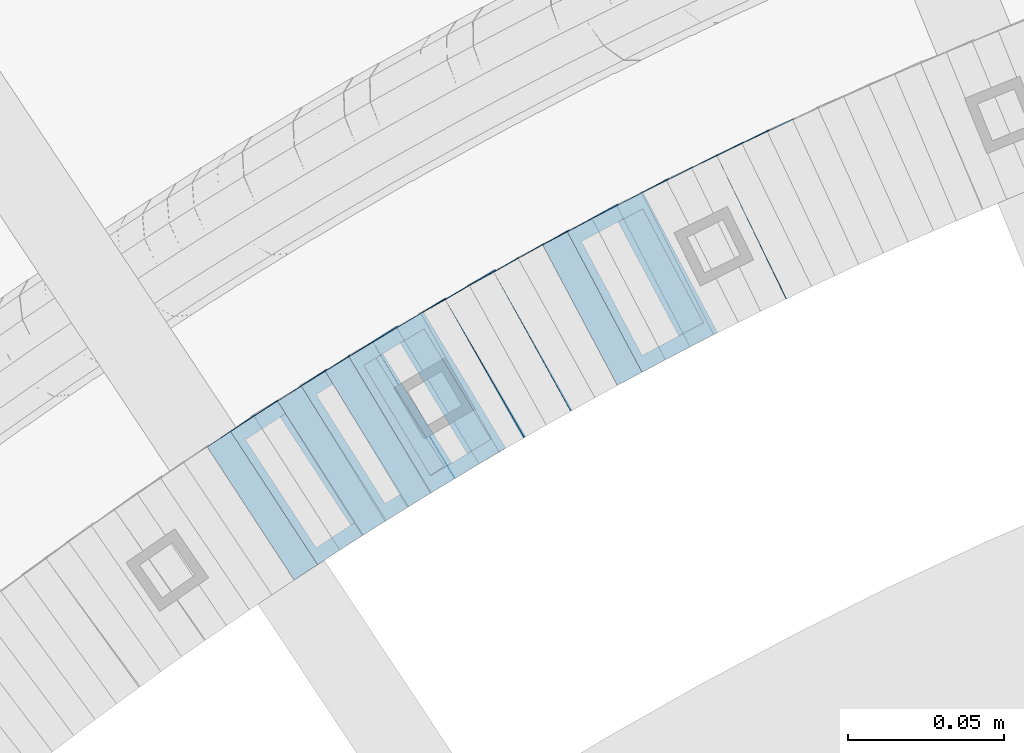
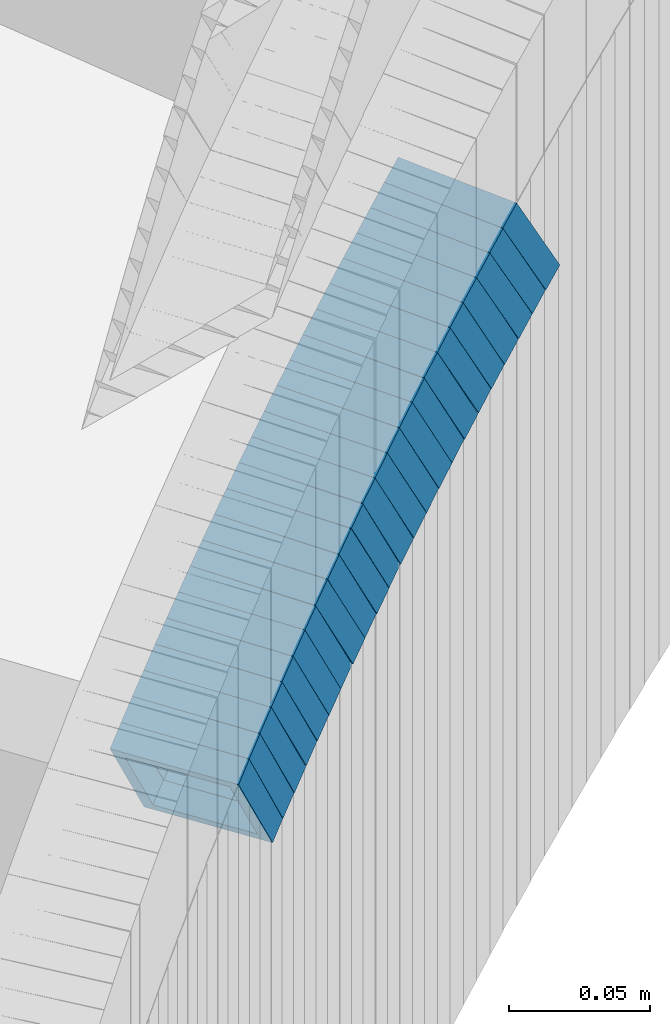
# One storey, part 748 of 975: 23 members.
"""IFC2X3 building model written with IfcOpenShell, lengths in millimetres."""

from ifc_helpers import new_model, si_unit, frame, origin_with_axes, place, context, subcontext, project, spatial, faceted_brep, material, type_object, element, save


model = new_model("IFC2X3")

# Units and contexts
model_context = context("Model", 3, precision=1e-05, world=origin_with_axes())
body_context = subcontext(model_context, "Body", "Model", "MODEL_VIEW")
ifc_project = project(units=[si_unit("LENGTHUNIT", "METRE", prefix="MILLI"), si_unit("AREAUNIT", "SQUARE_METRE"), si_unit("VOLUMEUNIT", "CUBIC_METRE"), si_unit("MASSUNIT", "GRAM", prefix="KILO"), si_unit("TIMEUNIT", "SECOND"), si_unit("PLANEANGLEUNIT", "RADIAN"), si_unit("SOLIDANGLEUNIT", "STERADIAN"), si_unit("THERMODYNAMICTEMPERATUREUNIT", "DEGREE_CELSIUS"), si_unit("LUMINOUSINTENSITYUNIT", "LUMEN")], contexts=[model_context])

# Site, building, storey
site_placement = place(None, origin_with_axes())
site = spatial("IfcSite", under=ifc_project, at=site_placement, CompositionType="ELEMENT")
building_placement = place(site_placement, origin_with_axes())
building = spatial("IfcBuilding", under=site, at=building_placement, Name="Undefined", CompositionType="ELEMENT")
storey_placement = place(building_placement, origin_with_axes())
storey = spatial("IfcBuildingStorey", under=building, at=storey_placement, Name="Undefined", CompositionType="ELEMENT", Elevation=0.0)

# Members
ifc_material = material()
member_type = type_object("IfcMemberType", Name="HSS2X2X.188_TUBES", PredefinedType="NOTDEFINED")
member_1_placement = place(storey_placement, frame((34127.8194134494, 4662.12892975427, 626.710672196454), z_axis=(-0.438202246944682, 0.898876404614467, -1.0214671419817e-10), x_axis=(0.756943389157108, 0.369009902076498, 0.539322165111767)))
element("IfcMember", 1, at=member_1_placement, inside=storey, type_object=member_type, material=ifc_material, Name="WALL", ObjectType="HSS2X2X.188_TUBES", context=body_context, shape_type="Brep", body=[
    faceted_brep([(0.0, 20.6374999999753, -20.6375000000298), (0.0, -20.6375000000153, -20.6375000000153), (10.5744976239494, -20.6375000000207, -20.6375000000335), (10.5744976239657, 20.6375000000098, -20.637500000008), (0.0, -20.6374999999825, 20.6375000000335), (10.5744976239639, -20.6375000000244, 20.6374999999753), (0.0, 20.6375000000116, 20.6375000000189), (10.5744976239803, 20.6374999999989, 20.6374999999935), (0.0, 25.3999999999724, -25.4000000000342), (0.0, 25.400000000016, 25.4000000000196), (10.5744976239857, 25.4000000000051, 25.4000000000015), (10.5744976239675, 25.4000000000124, -25.4000000000051), (0.0, -25.399999999976, 25.4000000000378), (10.5744976239639, -25.4000000000287, 25.3999999999724), (0.0, -25.400000000016, -25.4000000000196), (10.5744976239494, -25.4000000000215, -25.4000000000378)], [[[0, 1, 2, 3]], [[1, 4, 5, 2]], [[4, 6, 7, 5]], [[6, 0, 3, 7]], [[8, 9, 10, 11]], [[9, 12, 13, 10]], [[12, 14, 15, 13]], [[14, 8, 11, 15]], [[13, 15, 11, 10], [5, 7, 3, 2]], [[14, 12, 9, 8], [6, 4, 1, 0]]]),
])
member_2_placement = place(storey_placement, frame((34120.0954326913, 4658.41942418444, 620.988545204124), z_axis=(-0.447213595461908, 0.894427191018941, 1.31206434161868e-10), x_axis=(0.750454514252586, 0.375227257126378, 0.544079523183265)))
element("IfcMember", 2, at=member_2_placement, inside=storey, type_object=member_type, material=ifc_material, Name="WALL", ObjectType="HSS2X2X.188_TUBES", context=body_context, shape_type="Brep", body=[
    faceted_brep([(0.0, 20.6374999999753, -20.6375000000298), (0.0, -20.6375000000153, -20.6375000000153), (10.6625512894789, -20.6374999999625, -20.6374999999389), (10.6625512893879, 20.6374999999789, -20.6375000000371), (0.0, -20.6374999999825, 20.6375000000335), (10.6625512894352, -20.6374999999989, 20.6375000000153), (0.0, 20.6375000000116, 20.6375000000189), (10.6625512893443, 20.6374999999443, 20.6374999999134), (0.0, 25.3999999999724, -25.4000000000342), (0.0, 25.400000000016, 25.4000000000196), (10.6625512893297, 25.3999999999342, 25.3999999998996), (10.6625512893916, 25.399999999976, -25.4000000000415), (0.0, -25.399999999976, 25.4000000000378), (10.6625512894389, -25.399999999996, 25.400000000016), (0.0, -25.400000000016, -25.4000000000196), (10.6625512894971, -25.3999999999523, -25.3999999999214)], [[[0, 1, 2, 3]], [[1, 4, 5, 2]], [[4, 6, 7, 5]], [[6, 0, 3, 7]], [[8, 9, 10, 11]], [[9, 12, 13, 10]], [[12, 14, 15, 13]], [[14, 8, 11, 15]], [[13, 15, 11, 10], [5, 7, 3, 2]], [[14, 12, 9, 8], [6, 4, 1, 0]]]),
])
member_3_placement = place(storey_placement, frame((34112.2148513397, 4654.50712523634, 615.242339923612), z_axis=(-0.45172514319179, 0.892157158245315, -3.88070020562736e-11), x_axis=(0.750172808414512, 0.379834333209997, 0.541263925299295)))
element("IfcMember", 3, at=member_3_placement, inside=storey, type_object=member_type, material=ifc_material, Name="WALL", ObjectType="HSS2X2X.188_TUBES", context=body_context, shape_type="Brep", body=[
    faceted_brep([(0.0, 20.6374999999753, -20.6375000000298), (0.0, -20.6375000000153, -20.6375000000153), (10.5290075505945, -20.637499999968, -20.6375000000116), (10.5290075505436, 20.6374999999898, -20.637499999998), (0.0, -20.6374999999825, 20.6375000000335), (10.5290075505145, -20.6375000000189, 20.637500000008), (0.0, 20.6375000000116, 20.6375000000189), (10.5290075504672, 20.6374999999462, 20.6375000000198), (0.0, 25.3999999999724, -25.4000000000342), (0.0, 25.400000000016, 25.4000000000196), (10.5290075504563, 25.399999999936, 25.4000000000224), (10.5290075505472, 25.3999999999869, -25.3999999999987), (0.0, -25.399999999976, 25.4000000000378), (10.5290075505072, -25.4000000000196, 25.4000000000106), (0.0, -25.400000000016, -25.4000000000196), (10.5290075506091, -25.3999999999651, -25.4000000000151)], [[[0, 1, 2, 3]], [[1, 4, 5, 2]], [[4, 6, 7, 5]], [[6, 0, 3, 7]], [[8, 9, 10, 11]], [[9, 12, 13, 10]], [[12, 14, 15, 13]], [[14, 8, 11, 15]], [[13, 15, 11, 10], [5, 7, 3, 2]], [[14, 12, 9, 8], [6, 4, 1, 0]]]),
])
member_4_placement = place(storey_placement, frame((34104.1648866181, 4650.4568645653, 609.448813698615), z_axis=(-0.456090790845811, 0.889933250589977, -3.15709485221305e-11), x_axis=(0.751579683808389, 0.385184587901925, 0.535500524863708)))
element("IfcMember", 4, at=member_4_placement, inside=storey, type_object=member_type, material=ifc_material, Name="WALL", ObjectType="HSS2X2X.188_TUBES", context=body_context, shape_type="Brep", body=[
    faceted_brep([(0.0, 20.6374999999753, -20.6375000000298), (0.0, -20.6375000000153, -20.6375000000153), (10.6395488625676, -20.6374999999771, -20.6374999999716), (10.6395488625531, 20.6374999999916, -20.6375000000189), (0.0, -20.6374999999825, 20.6375000000335), (10.6395488625731, -20.6374999999844, 20.6375000000153), (0.0, 20.6375000000116, 20.6375000000189), (10.6395488625585, 20.6374999999825, 20.637499999968), (0.0, 25.3999999999724, -25.4000000000342), (0.0, 25.400000000016, 25.4000000000196), (10.6395488625567, 25.3999999999778, 25.3999999999614), (10.6395488625494, 25.3999999999887, -25.4000000000233), (0.0, -25.399999999976, 25.4000000000378), (10.6395488625749, -25.3999999999851, 25.400000000016), (0.0, -25.400000000016, -25.4000000000196), (10.6395488625658, -25.399999999976, -25.3999999999687)], [[[0, 1, 2, 3]], [[1, 4, 5, 2]], [[4, 6, 7, 5]], [[6, 0, 3, 7]], [[8, 9, 10, 11]], [[9, 12, 13, 10]], [[12, 14, 15, 13]], [[14, 8, 11, 15]], [[13, 15, 11, 10], [5, 7, 3, 2]], [[14, 12, 9, 8], [6, 4, 1, 0]]]),
])
member_5_placement = place(storey_placement, frame((34096.4342308046, 4646.52290312139, 603.810279514727), z_axis=(-0.460645080613961, 0.887584423988027, 2.15902332456608e-10), x_axis=(0.747448139909672, 0.387916122953114, 0.539298024934818)))
element("IfcMember", 5, at=member_5_placement, inside=storey, type_object=member_type, material=ifc_material, Name="WALL", ObjectType="HSS2X2X.188_TUBES", context=body_context, shape_type="Brep", body=[
    faceted_brep([(0.0, 20.6374999999753, -20.6375000000298), (0.0, -20.6375000000153, -20.6375000000153), (10.5744976239494, -20.6375000000207, -20.6375000000335), (10.5744976239657, 20.6375000000098, -20.637500000008), (0.0, -20.6374999999825, 20.6375000000335), (10.5744976239639, -20.6375000000244, 20.6374999999753), (0.0, 20.6375000000116, 20.6375000000189), (10.5744976239803, 20.6374999999989, 20.6374999999935), (0.0, 25.3999999999724, -25.4000000000342), (0.0, 25.400000000016, 25.4000000000196), (10.5744976239857, 25.4000000000051, 25.4000000000015), (10.5744976239675, 25.4000000000124, -25.4000000000051), (0.0, -25.399999999976, 25.4000000000378), (10.5744976239639, -25.4000000000287, 25.3999999999724), (0.0, -25.400000000016, -25.4000000000196), (10.5744976239494, -25.4000000000215, -25.4000000000378)], [[[0, 1, 2, 3]], [[1, 4, 5, 2]], [[4, 6, 7, 5]], [[6, 0, 3, 7]], [[8, 9, 10, 11]], [[9, 12, 13, 10]], [[12, 14, 15, 13]], [[14, 8, 11, 15]], [[13, 15, 11, 10], [5, 7, 3, 2]], [[14, 12, 9, 8], [6, 4, 1, 0]]]),
])
member_6_placement = place(storey_placement, frame((34088.7986642406, 4642.61597473966, 598.086574702748), z_axis=(-0.469427601862633, 0.882970965892706, -2.25941221287939e-11), x_axis=(0.740910855725047, 0.393901973853829, 0.54395986879809)))
element("IfcMember", 6, at=member_6_placement, inside=storey, type_object=member_type, material=ifc_material, Name="WALL", ObjectType="HSS2X2X.188_TUBES", context=body_context, shape_type="Brep", body=[
    faceted_brep([(0.0, 20.6374999999753, -20.6375000000298), (0.0, -20.6375000000153, -20.6375000000153), (10.6625512894789, -20.6374999999625, -20.6374999999389), (10.6625512893879, 20.6374999999789, -20.6375000000371), (0.0, -20.6374999999825, 20.6375000000335), (10.6625512894352, -20.6374999999989, 20.6375000000153), (0.0, 20.6375000000116, 20.6375000000189), (10.6625512893443, 20.6374999999443, 20.6374999999134), (0.0, 25.3999999999724, -25.4000000000342), (0.0, 25.400000000016, 25.4000000000196), (10.6625512893297, 25.3999999999342, 25.3999999998996), (10.6625512893916, 25.399999999976, -25.4000000000415), (0.0, -25.399999999976, 25.4000000000378), (10.6625512894389, -25.399999999996, 25.400000000016), (0.0, -25.400000000016, -25.4000000000196), (10.6625512894971, -25.3999999999523, -25.3999999999214)], [[[0, 1, 2, 3]], [[1, 4, 5, 2]], [[4, 6, 7, 5]], [[6, 0, 3, 7]], [[8, 9, 10, 11]], [[9, 12, 13, 10]], [[12, 14, 15, 13]], [[14, 8, 11, 15]], [[13, 15, 11, 10], [5, 7, 3, 2]], [[14, 12, 9, 8], [6, 4, 1, 0]]]),
])
member_7_placement = place(storey_placement, frame((34080.7494268012, 4638.33663331616, 592.277954916562), z_axis=(-0.469427601862633, 0.882970965892706, -2.25941221287939e-11), x_axis=(0.744686765943868, 0.395909419970168, 0.537305640959545)))
element("IfcMember", 7, at=member_7_placement, inside=storey, type_object=member_type, material=ifc_material, Name="WALL", ObjectType="HSS2X2X.188_TUBES", context=body_context, shape_type="Brep", body=[
    faceted_brep([(0.0, 20.6374999999753, -20.6375000000298), (0.0, -20.6375000000153, -20.6375000000153), (10.6061303028146, -20.6374999999571, -20.6374999999643), (10.6061303027491, 20.6374999999971, -20.6375000000007), (0.0, -20.6374999999825, 20.6375000000335), (10.6061303027855, -20.6374999999825, 20.6375000000116), (0.0, 20.6375000000116, 20.6375000000189), (10.6061303027236, 20.637499999968, 20.6374999999716), (0.0, 25.3999999999724, -25.4000000000342), (0.0, 25.400000000016, 25.4000000000196), (10.6061303027163, 25.3999999999651, 25.3999999999651), (10.6061303027454, 25.3999999999942, -25.4000000000051), (0.0, -25.399999999976, 25.4000000000378), (10.6061303027891, -25.3999999999796, 25.4000000000124), (0.0, -25.400000000016, -25.4000000000196), (10.6061303028182, -25.3999999999505, -25.3999999999542)], [[[0, 1, 2, 3]], [[1, 4, 5, 2]], [[4, 6, 7, 5]], [[6, 0, 3, 7]], [[8, 9, 10, 11]], [[9, 12, 13, 10]], [[12, 14, 15, 13]], [[14, 8, 11, 15]], [[13, 15, 11, 10], [5, 7, 3, 2]], [[14, 12, 9, 8], [6, 4, 1, 0]]]),
])
for number, where, z_axis, x_axis, name in (
    (8, (34073.2283409251, 4634.42367748613, 586.605965124926), (-0.482780509041048, 0.875741388818678, -7.90289504948305e-11), (0.737623694251176, 0.406638703138482, 0.539032699183548), "WALL"),
    (9, (34065.4283409251, 4630.12367748613, 580.905965124958), (-0.482780509041048, 0.875741388818678, -7.90289504948305e-11), (0.737623694251176, 0.406638703138482, 0.539032699183548), "WALL"),
):
    element("IfcMember", number, at=place(storey_placement, frame(where, z_axis=z_axis, x_axis=x_axis)), inside=storey, type_object=member_type, material=ifc_material, Name=name, ObjectType="HSS2X2X.188_TUBES", context=body_context, shape_type="Brep", body=[
        faceted_brep([(0.0, 20.6374999999753, -20.6375000000298), (0.0, -20.6375000000153, -20.6375000000153), (10.5744976239494, -20.6375000000207, -20.6375000000335), (10.5744976239657, 20.6375000000098, -20.637500000008), (0.0, -20.6374999999825, 20.6375000000335), (10.5744976239639, -20.6375000000244, 20.6374999999753), (0.0, 20.6375000000116, 20.6375000000189), (10.5744976239803, 20.6374999999989, 20.6374999999935), (0.0, 25.3999999999724, -25.4000000000342), (0.0, 25.400000000016, 25.4000000000196), (10.5744976239857, 25.4000000000051, 25.4000000000015), (10.5744976239675, 25.4000000000124, -25.4000000000051), (0.0, -25.399999999976, 25.4000000000378), (10.5744976239639, -25.4000000000287, 25.3999999999724), (0.0, -25.400000000016, -25.4000000000196), (10.5744976239494, -25.4000000000215, -25.4000000000378)], [[[0, 1, 2, 3]], [[1, 4, 5, 2]], [[4, 6, 7, 5]], [[6, 0, 3, 7]], [[8, 9, 10, 11]], [[9, 12, 13, 10]], [[12, 14, 15, 13]], [[14, 8, 11, 15]], [[13, 15, 11, 10], [5, 7, 3, 2]], [[14, 12, 9, 8], [6, 4, 1, 0]]]),
    ])
member_8_placement = place(storey_placement, frame((34057.8811351704, 4626.01860488152, 575.180674673501), z_axis=(-0.491321187370494, 0.870978467495522, 1.84759755939013e-10), x_axis=(0.731050131101433, 0.412387253057153, 0.543601379075286)))
element("IfcMember", 10, at=member_8_placement, inside=storey, type_object=member_type, material=ifc_material, Name="WALL", ObjectType="HSS2X2X.188_TUBES", context=body_context, shape_type="Brep", body=[
    faceted_brep([(0.0, 20.6374999999753, -20.6375000000298), (0.0, -20.6375000000153, -20.6375000000153), (10.6709887076922, -20.6374999999844, -20.6374999999825), (10.6709887076995, 20.6375000000171, -20.6374999999753), (0.0, -20.6374999999825, 20.6375000000335), (10.6709887076922, -20.6374999999971, 20.6375000000153), (0.0, 20.6375000000116, 20.6375000000189), (10.6709887076941, 20.6375000000025, 20.6375000000189), (0.0, 25.3999999999724, -25.4000000000342), (0.0, 25.400000000016, 25.4000000000196), (10.6709887076959, 25.3999999999996, 25.4000000000233), (10.6709887077013, 25.4000000000178, -25.3999999999724), (0.0, -25.399999999976, 25.4000000000378), (10.6709887076904, -25.3999999999978, 25.400000000016), (0.0, -25.400000000016, -25.4000000000196), (10.6709887076959, -25.3999999999796, -25.3999999999796)], [[[0, 1, 2, 3]], [[1, 4, 5, 2]], [[4, 6, 7, 5]], [[6, 0, 3, 7]], [[8, 9, 10, 11]], [[9, 12, 13, 10]], [[12, 14, 15, 13]], [[14, 8, 11, 15]], [[13, 15, 11, 10], [5, 7, 3, 2]], [[14, 12, 9, 8], [6, 4, 1, 0]]]),
])
member_9_placement = place(storey_placement, frame((34050.2012941132, 4621.71777799003, 569.432786794332), z_axis=(-0.496138938203287, 0.868243142212201, -4.57771420769859e-11), x_axis=(0.730391194976061, 0.417366396986338, 0.540679195982317)))
element("IfcMember", 11, at=member_9_placement, inside=storey, type_object=member_type, material=ifc_material, Name="WALL", ObjectType="HSS2X2X.188_TUBES", context=body_context, shape_type="Brep", body=[
    faceted_brep([(0.0, 20.6374999999753, -20.6375000000298), (0.0, -20.6375000000153, -20.6375000000153), (10.5422957651572, -20.6374999999771, -20.6374999999534), (10.5422957651481, 20.6375000000153, -20.6374999999789), (0.0, -20.6374999999825, 20.6375000000335), (10.5422957651535, -20.6374999999971, 20.6375000000298), (0.0, 20.6375000000116, 20.6375000000189), (10.5422957651444, 20.6374999999971, 20.6375000000044), (0.0, 25.3999999999724, -25.4000000000342), (0.0, 25.400000000016, 25.4000000000196), (10.5422957651426, 25.3999999999924, 25.3999999999905), (10.5422957651463, 25.4000000000178, -25.3999999999833), (0.0, -25.399999999976, 25.4000000000378), (10.5422957651499, -25.3999999999996, 25.4000000000269), (0.0, -25.400000000016, -25.4000000000196), (10.5422957651554, -25.3999999999742, -25.3999999999469)], [[[0, 1, 2, 3]], [[1, 4, 5, 2]], [[4, 6, 7, 5]], [[6, 0, 3, 7]], [[8, 9, 10, 11]], [[9, 12, 13, 10]], [[12, 14, 15, 13]], [[14, 8, 11, 15]], [[13, 15, 11, 10], [5, 7, 3, 2]], [[14, 12, 9, 8], [6, 4, 1, 0]]]),
])
member_10_placement = place(storey_placement, frame((34042.3355908175, 4617.2451372803, 563.638185626074), z_axis=(-0.499722453073496, 0.866185586288647, 5.10086692884215e-11), x_axis=(0.731886389219763, 0.422242147126705, 0.534840053160464)))
element("IfcMember", 12, at=member_10_placement, inside=storey, type_object=member_type, material=ifc_material, Name="WALL", ObjectType="HSS2X2X.188_TUBES", context=body_context, shape_type="Brep", body=[
    faceted_brep([(0.0, 20.6374999999753, -20.6375000000298), (0.0, -20.6375000000153, -20.6375000000153), (10.6625512894789, -20.6374999999625, -20.6374999999389), (10.6625512893879, 20.6374999999789, -20.6375000000371), (0.0, -20.6374999999825, 20.6375000000335), (10.6625512894352, -20.6374999999989, 20.6375000000153), (0.0, 20.6375000000116, 20.6375000000189), (10.6625512893443, 20.6374999999443, 20.6374999999134), (0.0, 25.3999999999724, -25.4000000000342), (0.0, 25.400000000016, 25.4000000000196), (10.6625512893297, 25.3999999999342, 25.3999999998996), (10.6625512893916, 25.399999999976, -25.4000000000415), (0.0, -25.399999999976, 25.4000000000378), (10.6625512894389, -25.399999999996, 25.400000000016), (0.0, -25.400000000016, -25.4000000000196), (10.6625512894971, -25.3999999999523, -25.3999999999214)], [[[0, 1, 2, 3]], [[1, 4, 5, 2]], [[4, 6, 7, 5]], [[6, 0, 3, 7]], [[8, 9, 10, 11]], [[9, 12, 13, 10]], [[12, 14, 15, 13]], [[14, 8, 11, 15]], [[13, 15, 11, 10], [5, 7, 3, 2]], [[14, 12, 9, 8], [6, 4, 1, 0]]]),
])
member_11_placement = place(storey_placement, frame((34035.0424664431, 4613.12575894957, 557.970879373378), z_axis=(-0.512855252124471, 0.858475095951155, -8.52943458085064e-11), x_axis=(0.72088657057977, 0.430659509749113, 0.543005468683689)))
element("IfcMember", 13, at=member_11_placement, inside=storey, type_object=member_type, material=ifc_material, Name="WALL", ObjectType="HSS2X2X.188_TUBES", context=body_context, shape_type="Brep", body=[
    faceted_brep([(0.0, 20.6374999999753, -20.6375000000298), (0.0, -20.6375000000153, -20.6375000000153), (10.6831643251735, -20.6375000000498, -20.6375000000953), (10.6831643252044, 20.637499999988, -20.6375000000226), (0.0, -20.6374999999825, 20.6375000000335), (10.6831643251935, -20.6375000000135, 20.637499999968), (0.0, 20.6375000000116, 20.6375000000189), (10.6831643252244, 20.6375000000226, 20.6375000000407), (0.0, 25.3999999999724, -25.4000000000342), (0.0, 25.400000000016, 25.4000000000196), (10.6831643252317, 25.4000000000306, 25.4000000000597), (10.6831643252044, 25.3999999999905, -25.4000000000196), (0.0, -25.399999999976, 25.4000000000378), (10.6831643251917, -25.400000000016, 25.3999999999614), (0.0, -25.400000000016, -25.4000000000196), (10.6831643251644, -25.400000000056, -25.4000000001179)], [[[0, 1, 2, 3]], [[1, 4, 5, 2]], [[4, 6, 7, 5]], [[6, 0, 3, 7]], [[8, 9, 10, 11]], [[9, 12, 13, 10]], [[12, 14, 15, 13]], [[14, 8, 11, 15]], [[13, 15, 11, 10], [5, 7, 3, 2]], [[14, 12, 9, 8], [6, 4, 1, 0]]]),
])
member_12_placement = place(storey_placement, frame((34027.3679576708, 4608.51869346286, 552.258363616012), z_axis=(-0.509492006949615, 0.86047538887202, -1.41016016641515e-11), x_axis=(0.722990271111197, 0.428086345065616, 0.542242703083148)))
element("IfcMember", 14, at=member_12_placement, inside=storey, type_object=member_type, material=ifc_material, Name="WALL", ObjectType="HSS2X2X.188_TUBES", context=body_context, shape_type="Brep", body=[
    faceted_brep([(0.0, 20.6374999999753, -20.6375000000298), (0.0, -20.6375000000153, -20.6375000000153), (10.5118980208099, -20.6374999999875, -20.637499999968), (10.5118980207899, 20.6374999999921, -20.6375000000189), (0.0, -20.6374999999825, 20.6375000000335), (10.5118980208281, -20.6374999999784, 20.637500000099), (0.0, 20.6375000000116, 20.6375000000189), (10.5118980208063, 20.6375000000016, 20.6375000000335), (0.0, 25.3999999999724, -25.4000000000342), (0.0, 25.400000000016, 25.4000000000196), (10.5118980208063, 25.4000000000005, 25.4000000000306), (10.5118980207862, 25.3999999999896, -25.4000000000378), (0.0, -25.399999999976, 25.4000000000378), (10.5118980208317, -25.3999999999746, 25.4000000001033), (0.0, -25.400000000016, -25.4000000000196), (10.5118980208135, -25.3999999999855, -25.3999999999724)], [[[0, 1, 2, 3]], [[1, 4, 5, 2]], [[4, 6, 7, 5]], [[6, 0, 3, 7]], [[8, 9, 10, 11]], [[9, 12, 13, 10]], [[12, 14, 15, 13]], [[14, 8, 11, 15]], [[13, 15, 11, 10], [5, 7, 3, 2]], [[14, 12, 9, 8], [6, 4, 1, 0]]]),
])
member_13_placement = place(storey_placement, frame((34019.689729153, 4604.04599234663, 546.427238584241), z_axis=(-0.521001549732899, 0.853555730562403, 0.0), x_axis=(0.721582620777206, 0.440446534864126, 0.534158563835199)))
element("IfcMember", 15, at=member_13_placement, inside=storey, type_object=member_type, material=ifc_material, Name="WALL", ObjectType="HSS2X2X.188_TUBES", context=body_context, shape_type="Brep", body=[
    faceted_brep([(0.0, 20.6374999999753, -20.6375000000298), (0.0, -20.6375000000153, -20.6375000000153), (10.6709887076922, -20.6374999999844, -20.6374999999825), (10.6709887076995, 20.6375000000171, -20.6374999999753), (0.0, -20.6374999999825, 20.6375000000335), (10.6709887076922, -20.6374999999971, 20.6375000000153), (0.0, 20.6375000000116, 20.6375000000189), (10.6709887076941, 20.6375000000025, 20.6375000000189), (0.0, 25.3999999999724, -25.4000000000342), (0.0, 25.400000000016, 25.4000000000196), (10.6709887076959, 25.3999999999996, 25.4000000000233), (10.6709887077013, 25.4000000000178, -25.3999999999724), (0.0, -25.399999999976, 25.4000000000378), (10.6709887076904, -25.3999999999978, 25.400000000016), (0.0, -25.400000000016, -25.4000000000196), (10.6709887076959, -25.3999999999796, -25.3999999999796)], [[[0, 1, 2, 3]], [[1, 4, 5, 2]], [[4, 6, 7, 5]], [[6, 0, 3, 7]], [[8, 9, 10, 11]], [[9, 12, 13, 10]], [[12, 14, 15, 13]], [[14, 8, 11, 15]], [[13, 15, 11, 10], [5, 7, 3, 2]], [[14, 12, 9, 8], [6, 4, 1, 0]]]),
])
member_14_placement = place(storey_placement, frame((34012.3070207709, 4599.5179348861, 540.83158076795), z_axis=(-0.517802679254994, 0.855500079109494, -1.05409526440781e-10), x_axis=(0.7163438721687, 0.433576554102227, 0.546683481128881)))
element("IfcMember", 16, at=member_14_placement, inside=storey, type_object=member_type, material=ifc_material, Name="WALL", ObjectType="HSS2X2X.188_TUBES", context=body_context, shape_type="Brep", body=[
    faceted_brep([(0.0, 20.6374999999753, -20.6375000000298), (0.0, -20.6375000000153, -20.6375000000153), (10.6061303028146, -20.6374999999571, -20.6374999999643), (10.6061303027491, 20.6374999999971, -20.6375000000007), (0.0, -20.6374999999825, 20.6375000000335), (10.6061303027855, -20.6374999999825, 20.6375000000116), (0.0, 20.6375000000116, 20.6375000000189), (10.6061303027236, 20.637499999968, 20.6374999999716), (0.0, 25.3999999999724, -25.4000000000342), (0.0, 25.400000000016, 25.4000000000196), (10.6061303027163, 25.3999999999651, 25.3999999999651), (10.6061303027454, 25.3999999999942, -25.4000000000051), (0.0, -25.399999999976, 25.4000000000378), (10.6061303027891, -25.3999999999796, 25.4000000000124), (0.0, -25.400000000016, -25.4000000000196), (10.6061303028182, -25.3999999999505, -25.3999999999542)], [[[0, 1, 2, 3]], [[1, 4, 5, 2]], [[4, 6, 7, 5]], [[6, 0, 3, 7]], [[8, 9, 10, 11]], [[9, 12, 13, 10]], [[12, 14, 15, 13]], [[14, 8, 11, 15]], [[13, 15, 11, 10], [5, 7, 3, 2]], [[14, 12, 9, 8], [6, 4, 1, 0]]]),
])
member_15_placement = place(storey_placement, frame((34004.7395907762, 4595.0456749426, 534.949194342251), z_axis=(-0.533992991124615, 0.845488903197308, 0.0), x_axis=(0.714032211209445, 0.45096771213215, 0.53552415815689)))
element("IfcMember", 17, at=member_15_placement, inside=storey, type_object=member_type, material=ifc_material, Name="WALL", ObjectType="HSS2X2X.188_TUBES", context=body_context, shape_type="Brep", body=[
    faceted_brep([(0.0, 20.6374999999753, -20.6375000000298), (0.0, -20.6375000000153, -20.6375000000153), (10.6395488625676, -20.6374999999771, -20.6374999999716), (10.6395488625531, 20.6374999999916, -20.6375000000189), (0.0, -20.6374999999825, 20.6375000000335), (10.6395488625731, -20.6374999999844, 20.6375000000153), (0.0, 20.6375000000116, 20.6375000000189), (10.6395488625585, 20.6374999999825, 20.637499999968), (0.0, 25.3999999999724, -25.4000000000342), (0.0, 25.400000000016, 25.4000000000196), (10.6395488625567, 25.3999999999778, 25.3999999999614), (10.6395488625494, 25.3999999999887, -25.4000000000233), (0.0, -25.399999999976, 25.4000000000378), (10.6395488625749, -25.3999999999851, 25.400000000016), (0.0, -25.400000000016, -25.4000000000196), (10.6395488625658, -25.399999999976, -25.3999999999687)], [[[0, 1, 2, 3]], [[1, 4, 5, 2]], [[4, 6, 7, 5]], [[6, 0, 3, 7]], [[8, 9, 10, 11]], [[9, 12, 13, 10]], [[12, 14, 15, 13]], [[14, 8, 11, 15]], [[13, 15, 11, 10], [5, 7, 3, 2]], [[14, 12, 9, 8], [6, 4, 1, 0]]]),
])
member_16_placement = place(storey_placement, frame((33989.8014909997, 4585.64559602666, 523.507532911175), z_axis=(-0.539053696363204, 0.842271400700016, -2.99337671094691e-10), x_axis=(0.709380442229586, 0.454003483147114, 0.539129136174669)))
element("IfcMember", 18, at=member_16_placement, inside=storey, type_object=member_type, material=ifc_material, Name="WALL", ObjectType="HSS2X2X.188_TUBES", context=body_context, shape_type="Brep", body=[
    faceted_brep([(0.0, 20.6374999999753, -20.6375000000298), (0.0, -20.6375000000153, -20.6375000000153), (10.5744976239494, -20.6375000000207, -20.6375000000335), (10.5744976239657, 20.6375000000098, -20.637500000008), (0.0, -20.6374999999825, 20.6375000000335), (10.5744976239639, -20.6375000000244, 20.6374999999753), (0.0, 20.6375000000116, 20.6375000000189), (10.5744976239803, 20.6374999999989, 20.6374999999935), (0.0, 25.3999999999724, -25.4000000000342), (0.0, 25.400000000016, 25.4000000000196), (10.5744976239857, 25.4000000000051, 25.4000000000015), (10.5744976239675, 25.4000000000124, -25.4000000000051), (0.0, -25.399999999976, 25.4000000000378), (10.5744976239639, -25.4000000000287, 25.3999999999724), (0.0, -25.400000000016, -25.4000000000196), (10.5744976239494, -25.4000000000215, -25.4000000000378)], [[[0, 1, 2, 3]], [[1, 4, 5, 2]], [[4, 6, 7, 5]], [[6, 0, 3, 7]], [[8, 9, 10, 11]], [[9, 12, 13, 10]], [[12, 14, 15, 13]], [[14, 8, 11, 15]], [[13, 15, 11, 10], [5, 7, 3, 2]], [[14, 12, 9, 8], [6, 4, 1, 0]]]),
])
member_17_placement = place(storey_placement, frame((33982.5241640602, 4581.04352100842, 517.778319469282), z_axis=(-0.546948584002501, 0.837166200021035, 6.09270500717684e-12), x_axis=(0.702747648925298, 0.459128463951135, 0.543458181942123)))
element("IfcMember", 19, at=member_17_placement, inside=storey, type_object=member_type, material=ifc_material, Name="WALL", ObjectType="HSS2X2X.188_TUBES", context=body_context, shape_type="Brep", body=[
    faceted_brep([(0.0, 20.6374999999753, -20.6375000000298), (0.0, -20.6375000000153, -20.6375000000153), (10.6709887076922, -20.6374999999844, -20.6374999999825), (10.6709887076995, 20.6375000000171, -20.6374999999753), (0.0, -20.6374999999825, 20.6375000000335), (10.6709887076922, -20.6374999999971, 20.6375000000153), (0.0, 20.6375000000116, 20.6375000000189), (10.6709887076941, 20.6375000000025, 20.6375000000189), (0.0, 25.3999999999724, -25.4000000000342), (0.0, 25.400000000016, 25.4000000000196), (10.6709887076959, 25.3999999999996, 25.4000000000233), (10.6709887077013, 25.4000000000178, -25.3999999999724), (0.0, -25.399999999976, 25.4000000000378), (10.6709887076904, -25.3999999999978, 25.400000000016), (0.0, -25.400000000016, -25.4000000000196), (10.6709887076959, -25.3999999999796, -25.3999999999796)], [[[0, 1, 2, 3]], [[1, 4, 5, 2]], [[4, 6, 7, 5]], [[6, 0, 3, 7]], [[8, 9, 10, 11]], [[9, 12, 13, 10]], [[12, 14, 15, 13]], [[14, 8, 11, 15]], [[13, 15, 11, 10], [5, 7, 3, 2]], [[14, 12, 9, 8], [6, 4, 1, 0]]]),
])
member_18_placement = place(storey_placement, frame((33974.882691395, 4576.05109220051, 511.969859485467), z_axis=(-0.546948584002501, 0.837166200021035, 6.09270500717684e-12), x_axis=(0.706322413933297, 0.461463976956474, 0.536805034949334)))
element("IfcMember", 20, at=member_18_placement, inside=storey, type_object=member_type, material=ifc_material, Name="WALL", ObjectType="HSS2X2X.188_TUBES", context=body_context, shape_type="Brep", body=[
    faceted_brep([(0.0, 20.6374999999753, -20.6375000000298), (0.0, -20.6375000000153, -20.6375000000153), (10.6216759506497, -20.637499999968, -20.6374999999534), (10.6216759506497, 20.6375000000262, -20.6374999999643), (0.0, -20.6374999999825, 20.6375000000335), (10.6216759506169, -20.6374999999935, 20.637500000008), (0.0, 20.6375000000116, 20.6375000000189), (10.6216759506242, 20.6375000000007, 20.6374999999971), (0.0, 25.3999999999724, -25.4000000000342), (0.0, 25.400000000016, 25.4000000000196), (10.6216759506169, 25.3999999999978, 25.3999999999869), (10.6216759506533, 25.4000000000269, -25.3999999999614), (0.0, -25.399999999976, 25.4000000000378), (10.6216759506242, -25.3999999999942, 25.4000000000051), (0.0, -25.400000000016, -25.4000000000196), (10.6216759506569, -25.3999999999614, -25.3999999999432)], [[[0, 1, 2, 3]], [[1, 4, 5, 2]], [[4, 6, 7, 5]], [[6, 0, 3, 7]], [[8, 9, 10, 11]], [[9, 12, 13, 10]], [[12, 14, 15, 13]], [[14, 8, 11, 15]], [[13, 15, 11, 10], [5, 7, 3, 2]], [[14, 12, 9, 8], [6, 4, 1, 0]]]),
])
member_19_placement = place(storey_placement, frame((33997.2824091458, 4590.33587601815, 529.2572453416), z_axis=(-0.533992991124615, 0.845488903197308, 0.0), x_axis=(0.710435520923929, 0.448696118951844, 0.542174476941785)))
element("IfcMember", 21, at=member_19_placement, inside=storey, type_object=member_type, material=ifc_material, Name="WALL", ObjectType="HSS2X2X.188_TUBES", context=body_context, shape_type="Brep", body=[
    faceted_brep([(0.0, 20.6374999999753, -20.6375000000298), (0.0, -20.6375000000153, -20.6375000000153), (10.6985980389491, -20.6375000000317, -20.6375000000698), (10.6985980389982, 20.6375000000116, -20.6374999999643), (0.0, -20.6374999999825, 20.6375000000335), (10.6985980389818, -20.6374999999989, 20.6374999999789), (0.0, 20.6375000000116, 20.6375000000189), (10.6985980390309, 20.6375000000407, 20.6375000000808), (0.0, 25.3999999999724, -25.4000000000342), (0.0, 25.400000000016, 25.4000000000196), (10.6985980390382, 25.4000000000487, 25.4000000000997), (10.6985980390036, 25.4000000000142, -25.3999999999542), (0.0, -25.399999999976, 25.4000000000378), (10.6985980389763, -25.4000000000033, 25.3999999999724), (0.0, -25.400000000016, -25.4000000000196), (10.6985980389418, -25.400000000036, -25.4000000000851)], [[[0, 1, 2, 3]], [[1, 4, 5, 2]], [[4, 6, 7, 5]], [[6, 0, 3, 7]], [[8, 9, 10, 11]], [[9, 12, 13, 10]], [[12, 14, 15, 13]], [[14, 8, 11, 15]], [[13, 15, 11, 10], [5, 7, 3, 2]], [[14, 12, 9, 8], [6, 4, 1, 0]]]),
])
member_20_placement = place(storey_placement, frame((33967.4603465771, 4571.25374080981, 506.23213828578), z_axis=(-0.554700196225226, 0.832050294337846, 0.0), x_axis=(0.703241758862651, 0.468827838908325, 0.534463736895512)))
element("IfcMember", 22, at=member_20_placement, inside=storey, type_object=member_type, material=ifc_material, Name="WALL", ObjectType="HSS2X2X.188_TUBES", context=body_context, shape_type="Brep", body=[
    faceted_brep([(0.0, 20.6374999999753, -20.6375000000298), (0.0, -20.6375000000153, -20.6375000000153), (10.6625512894789, -20.6374999999625, -20.6374999999389), (10.6625512893879, 20.6374999999789, -20.6375000000371), (0.0, -20.6374999999825, 20.6375000000335), (10.6625512894352, -20.6374999999989, 20.6375000000153), (0.0, 20.6375000000116, 20.6375000000189), (10.6625512893443, 20.6374999999443, 20.6374999999134), (0.0, 25.3999999999724, -25.4000000000342), (0.0, 25.400000000016, 25.4000000000196), (10.6625512893297, 25.3999999999342, 25.3999999998996), (10.6625512893916, 25.399999999976, -25.4000000000415), (0.0, -25.399999999976, 25.4000000000378), (10.6625512894389, -25.399999999996, 25.400000000016), (0.0, -25.400000000016, -25.4000000000196), (10.6625512894971, -25.3999999999523, -25.3999999999214)], [[[0, 1, 2, 3]], [[1, 4, 5, 2]], [[4, 6, 7, 5]], [[6, 0, 3, 7]], [[8, 9, 10, 11]], [[9, 12, 13, 10]], [[12, 14, 15, 13]], [[14, 8, 11, 15]], [[13, 15, 11, 10], [5, 7, 3, 2]], [[14, 12, 9, 8], [6, 4, 1, 0]]]),
])
member_21_placement = place(storey_placement, frame((33960.358837234, 4566.55659273897, 500.598030349046), z_axis=(-0.559857410943981, 0.8285889689171, 0.0), x_axis=(0.694904609115979, 0.469530142078525, 0.54465496409111)))
element("IfcMember", 23, at=member_21_placement, inside=storey, type_object=member_type, material=ifc_material, Name="WALL", ObjectType="HSS2X2X.188_TUBES", context=body_context, shape_type="Brep", body=[
    faceted_brep([(0.0, 20.6374999999753, -20.6375000000298), (0.0, -20.6375000000153, -20.6375000000153), (10.648004507897, -20.6374999999862, -20.637499999968), (10.6480045078188, 20.6374999999771, -20.6375000000808), (0.0, -20.6374999999825, 20.6375000000335), (10.6480045079406, -20.6374999999698, 20.6375000001062), (0.0, 20.6375000000116, 20.6375000000189), (10.6480045078679, 20.6374999999935, 20.6375000000007), (0.0, 25.3999999999724, -25.4000000000342), (0.0, 25.400000000016, 25.4000000000196), (10.6480045078661, 25.3999999999905, 25.4000000000015), (10.648004507806, 25.3999999999705, -25.4000000000997), (0.0, -25.399999999976, 25.4000000000378), (10.6480045079552, -25.3999999999633, 25.4000000001288), (0.0, -25.400000000016, -25.4000000000196), (10.6480045078988, -25.3999999999814, -25.3999999999651)], [[[0, 1, 2, 3]], [[1, 4, 5, 2]], [[4, 6, 7, 5]], [[6, 0, 3, 7]], [[8, 9, 10, 11]], [[9, 12, 13, 10]], [[12, 14, 15, 13]], [[14, 8, 11, 15]], [[13, 15, 11, 10], [5, 7, 3, 2]], [[14, 12, 9, 8], [6, 4, 1, 0]]]),
])

save(model, "model.ifc")
